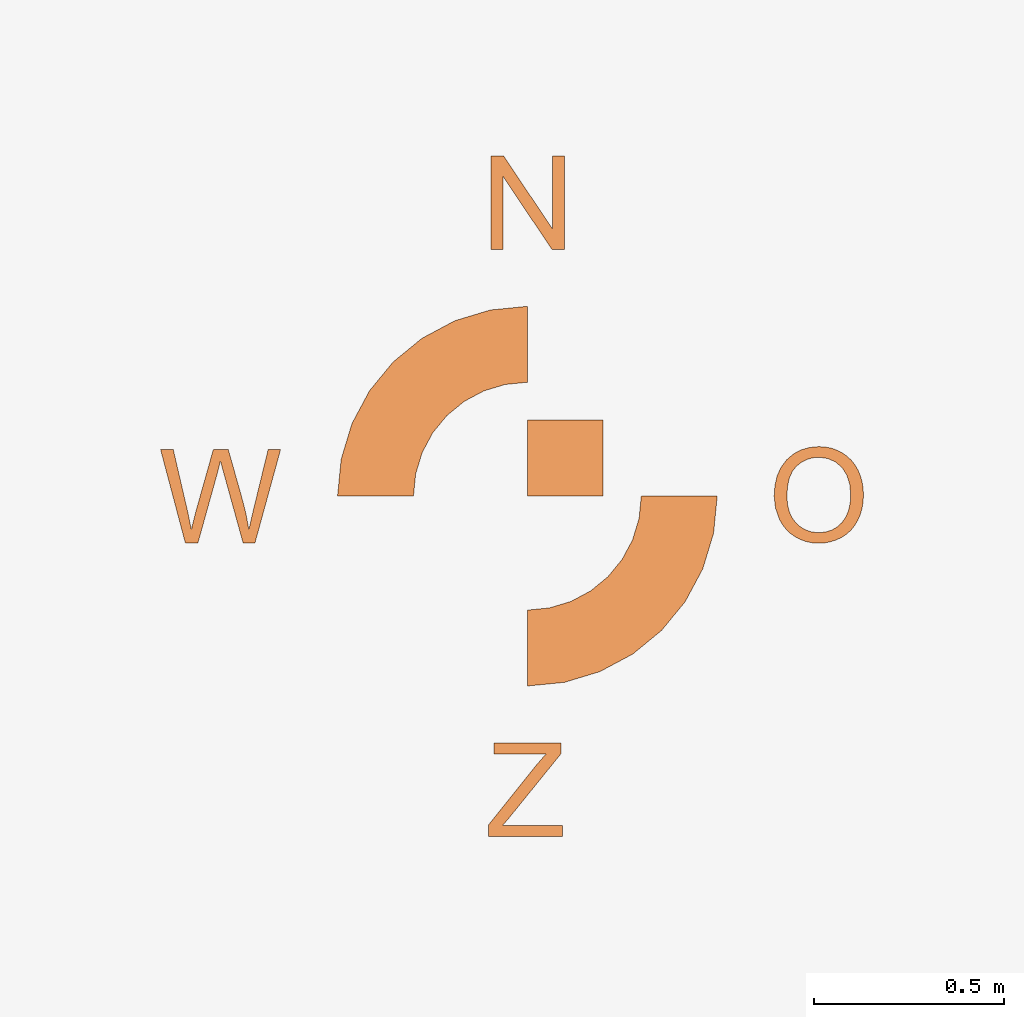
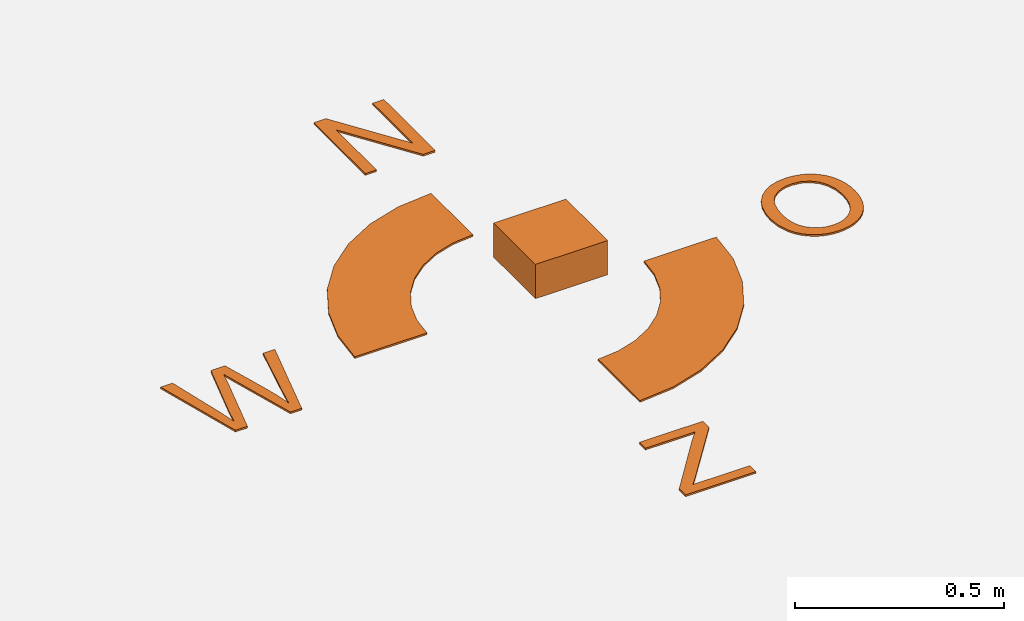
# Not in any storey, part 2 of 2: 1 proxy.
"""IFC4 model written with IfcOpenShell, lengths in metres."""

from ifc_helpers import new_model, entity, si_unit, converted_unit, direction, frame, origin, place, context, project, spatial, indexed_curve, outline, extrude, element, save


model = new_model("IFC4")

# Units and contexts
model_context = context("Model", 3, precision=1e-05, world=origin(), true_north=direction((0.0, 1.0)))
ifc_project = project(units=[si_unit("LENGTHUNIT", "METRE"), si_unit("AREAUNIT", "SQUARE_METRE"), si_unit("VOLUMEUNIT", "CUBIC_METRE"), converted_unit("PLANEANGLEUNIT", "DEGREE", entity("IfcPlaneAngleMeasure", 0.017453292519943278), si_unit("PLANEANGLEUNIT", "RADIAN"), dimensions=[0, 0, 0, 0, 0, 0, 0])], contexts=[model_context])

# Site
placement = place(None, origin())
site = spatial("IfcSite", under=ifc_project, at=placement, CompositionType="ELEMENT")

# Proxy
element("IfcBuildingElementProxy", 1, at=placement, inside=site, Name="GEO", PredefinedType="ELEMENT", context=model_context, shape_type="SweptSolid", body=[
    extrude(outline(indexed_curve([(-0.1, -0.1), (0.1, -0.1), (0.1, 0.1), (-0.1, 0.1), (-0.1, -0.1)], self_intersect=False)), frame((0.1, 0.1, 0.0), z_axis=(0.0, 0.0, 1.0), x_axis=(0.0, 1.0, 0.0)), (0.0, 0.0, 1.0), 0.1),
    extrude(outline(indexed_curve([(-0.01754690784267051, -0.12878897520169705), (0.014171609326943764, -0.12878897520169705), (0.0450055357424633, -0.12160411282425124), (0.05953297779926512, -0.1153077744388467), (0.07272367293119829, -0.10719605284880389), (0.08457762113826271, -0.09726894805412116), (0.09509482242045839, -0.08552646005479927), (0.1039533606410096, -0.0723016953265624), (0.11083131966313912, -0.0579277603451363), (0.11572869948684705, -0.042404655110520065), (0.11864550011213441, -0.02573237962271367), (0.11945031815293423, -0.009984110365049982), (0.11830956835281349, 0.005433157530156749), (0.1152232507117742, 0.020519424062906168), (0.11019136522981532, 0.03527468923319824), (0.1032089815100733, 0.04918281250647061), (0.09427116915568506, 0.06172765334815933), (0.08337792816665071, 0.0729092117582663), (0.0705292585429701, 0.08272748773678976), (0.05610867868335321, 0.09098147066554309), (0.0404997069865093, 0.09747014992633539), (0.02370234345243865, 0.10219352551916897), (0.005716588081141443, 0.10515159744404348), (-0.012228588462038727, 0.10625453830192368), (-0.029404124515073845, 0.10546836159308562), (-0.04581002007796403, 0.10279306731752633), (-0.06144627515070897, 0.09822865547524892), (-0.07599113978968514, 0.09182354367140377), (-0.0891228640512693, 0.0836261495111451), (-0.10084144793546082, 0.07363647299447158), (-0.11114689144226093, 0.06185451412138339), (-0.11978206606558495, 0.04864697808331044), (-0.1264898432993523, 0.03438057007168013), (-0.1312702231435611, 0.0190552900864913), (-0.13412320559821211, 0.0026711381277459293), (-0.1347250464018496, -0.022210442029596093), (-0.13076034255108251, -0.045197918825638034), (-0.12222909404591169, -0.06629129226037885), (-0.10913130088633619, -0.08549056233381865), (-0.09187147720602429, -0.10188587693265298), (-0.07085413713864268, -0.1145673839435784), (-0.04607928068419126, -0.1235350833665922), (-0.01754690784267051, -0.12878897520169705)], self_intersect=False), holes=[indexed_curve([(-0.013324272218916678, -0.09551754921327144), (-0.038756228700277555, -0.09111085467290425), (-0.05989547144516335, -0.08405188360862821), (-0.07674200045357377, -0.07434063602044125), (-0.08929581572550882, -0.0619771119083456), (-0.0981626913025538, -0.04785321452515381), (-0.10394840122629294, -0.03286084712367958), (-0.1066529454967262, -0.017000009703920863), (-0.10627632411385363, -0.00027070226588106304), (-0.10064802680457878, 0.022362256836597177), (-0.08916108847638943, 0.04193659715681769), (-0.07250587548559359, 0.057369514907236775), (-0.051372754188499146, 0.06757820630030774), (-0.026386721634686323, 0.07244267987978222), (0.0018272251262649371, 0.07184294418941255), (0.02389814668517629, 0.06788549743964743), (0.04295282871576932, 0.0612808153582714), (0.05899127121804382, 0.05202889794528376), (0.07201347419200016, 0.0401297452006861), (0.08183352289748637, 0.026278986263953738), (0.08826550259435072, 0.01117225027456344), (0.09130941328259361, -0.005190462767483886), (0.09096525496221466, -0.022809152862189014), (0.08746037986610529, -0.03979007673341377), (0.08094768569474736, -0.05490603644277885), (0.07142717244814112, -0.06815703199028277), (0.058898840126286295, -0.07954306337592608), (0.04386071421010187, -0.08838163071929508), (0.02681082018050657, -0.09399023413997569), (0.0077491580375004055, -0.09636887363796776), (-0.013324272218916678, -0.09551754921327144)], self_intersect=False)]), frame((0.7802408554501611, -0.0031413680495672542, 0.0), z_axis=(0.0, 0.0, 1.0), x_axis=(0.1110117078214559, -0.9938190985921752, 0.0)), (0.0, 0.0, 1.0), 0.005000000000000003),
    extrude(outline(indexed_curve([(-0.09706852224457868, -0.12200983679856901), (0.0972641403979433, -0.12200983679856901), (0.09726414039794332, -0.09300245919964216), (-0.05967750950145318, -0.09300245919964216), (-0.04475463894477981, -0.07573217080259413), (0.0932399955287279, 0.09479096803040488), (0.0932399955287279, 0.12379834562933077), (-0.08281634249944107, 0.12379834562933077), (-0.08281634249944107, 0.09479096803040488), (0.054339928459646816, 0.09479096803040488), (0.028853677621283314, 0.06561591772859386), (-0.09706852224457868, -0.09182875027945506), (-0.09706852224457868, -0.12200983679856901)], self_intersect=False)), frame((-0.004911826514644307, -0.7737983456293308, 0.0)), (0.0, 0.0, 1.0), 0.005),
    extrude(outline(indexed_curve([(-0.15075632809638098, -0.1621748934283883), (-0.05273918252840692, -0.16217489342838842), (0.04339457247257978, -0.14305268532892906), (0.13395059097624273, -0.10554315046173834), (0.21544885868453204, -0.05108772661946702), (0.28475743422710753, 0.01822086140168992), (0.33921284550800357, 0.09971913395564004), (0.1628285942214431, 0.19399845899410262), (0.13015534745290555, 0.1450994954617335), (0.08857020212736047, 0.10351434264903847), (0.039671233798808034, 0.07084109921982298), (-0.014662377666214269, 0.04833536497644355), (-0.0723426383703842, 0.03686205099291569), (-0.13115292607399417, 0.03686203766985063), (-0.18883318594719728, 0.048335348750862026), (-0.24316681059811115, 0.07084105738737094), (-0.3374461356365749, -0.10554319389918869), (-0.24689009455171906, -0.14305270829337066), (-0.15075632809638098, -0.1621748934283883)], self_intersect=False)), frame((0.24814822927580932, -0.24784822927580935, 0.0), z_axis=(0.0, 0.0, 1.0), x_axis=(0.8819213089994057, 0.4713966532897481, 0.0)), (0.0, 0.0, 1.0), 0.005),
    extrude(outline(indexed_curve([(-0.09543930248155583, -0.12922744802146238), (-0.06224010731052983, -0.12922744802146238), (-0.01009389671361486, 0.0580629610999331), (-0.0028839704896048645, 0.086902665995976), (0.004828973843058156, 0.0580629610999331), (0.05663983903420507, -0.12922744802146238), (0.08799463447350815, -0.1292274480214624), (0.1553990610328642, 0.1165807344064386), (0.12270288397049012, 0.11658073440643858), (0.08413816230717609, -0.0413669517102615), (0.07189805499664614, -0.09485454393024798), (0.0641851106639842, -0.052726777330650496), (0.052783366867874104, -0.007832411133467327), (0.017572099262240192, 0.1165807344064386), (-0.021663313212608986, 0.1165807344064386), (-0.06844399731723688, -0.04941524144869199), (-0.07951039570757894, -0.09485454393024798), (-0.08990610328638488, -0.044552733065056895), (-0.12729711602951085, 0.1165807344064386), (-0.1606639839034198, 0.11658073440643861), (-0.09543930248155583, -0.12922744802146238)], self_intersect=False)), frame((-0.8050990610328631, 0.006323356807511399, 0.0)), (0.0, 0.0, 1.0), 0.005),
    extrude(outline(indexed_curve([(-0.09683098591549295, -0.12292085848423871), (-0.06564386317907446, -0.12292085848423871), (-0.06564386317907449, 0.07023809523809511), (0.06346411804158285, -0.12292085848423871), (0.09683098591549293, -0.12292085848423871), (0.09683098591549293, 0.12288732394366216), (0.06564386317907445, 0.12288732394366216), (0.06564386317907446, -0.07010395707578777), (-0.06346411804158275, 0.12288732394366216), (-0.09683098591549295, 0.12288732394366216), (-0.09683098591549295, -0.12292085848423871)], self_intersect=False)), frame((0.0013898725687483532, 0.7729208584842387, 0.0)), (0.0, 0.0, 1.0), 0.005),
    extrude(outline(indexed_curve([(0.17335285921348753, -0.22664417561528874), (0.27137000183175236, -0.22664417561528874), (0.25176654505094487, -0.027607245087631224), (0.19295625947998613, -0.027607245087630898), (0.13527599907876628, -0.016133936661140432), (0.08094237755605367, 0.006371785100406648), (0.03204340443699104, 0.0390450132324235), (-0.00954174567737172, 0.08063016320968752), (-0.04221500470846998, 0.12952912111339243), (-0.06472073362161465, 0.1838627332912143), (-0.07619406849171109, 0.2415429922703179), (-0.2752309990193686, 0.22193953548951065), (-0.2561087742358753, 0.12580577052433842), (-0.21859922604729998, 0.03524975022796986), (-0.16414381312763363, -0.0462485247785728), (-0.09483522166485055, -0.11555708732775426), (-0.013336951931909173, -0.17001247938148464), (0.07721909187812213, -0.20752199490447024), (0.17335285921348753, -0.22664417561528874)], self_intersect=False)), frame((-0.24754822927580927, 0.24784822927580938, 0.0), z_axis=(0.0, 0.0, 1.0), x_axis=(-0.09801728974632228, -0.9951847119559191, 0.0)), (0.0, 0.0, 1.0), 0.005),
])

save(model, "model.ifc")
